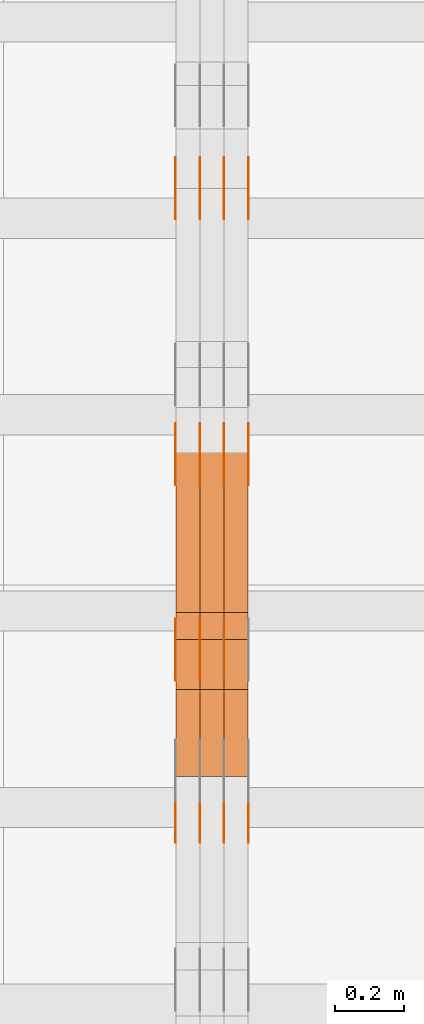
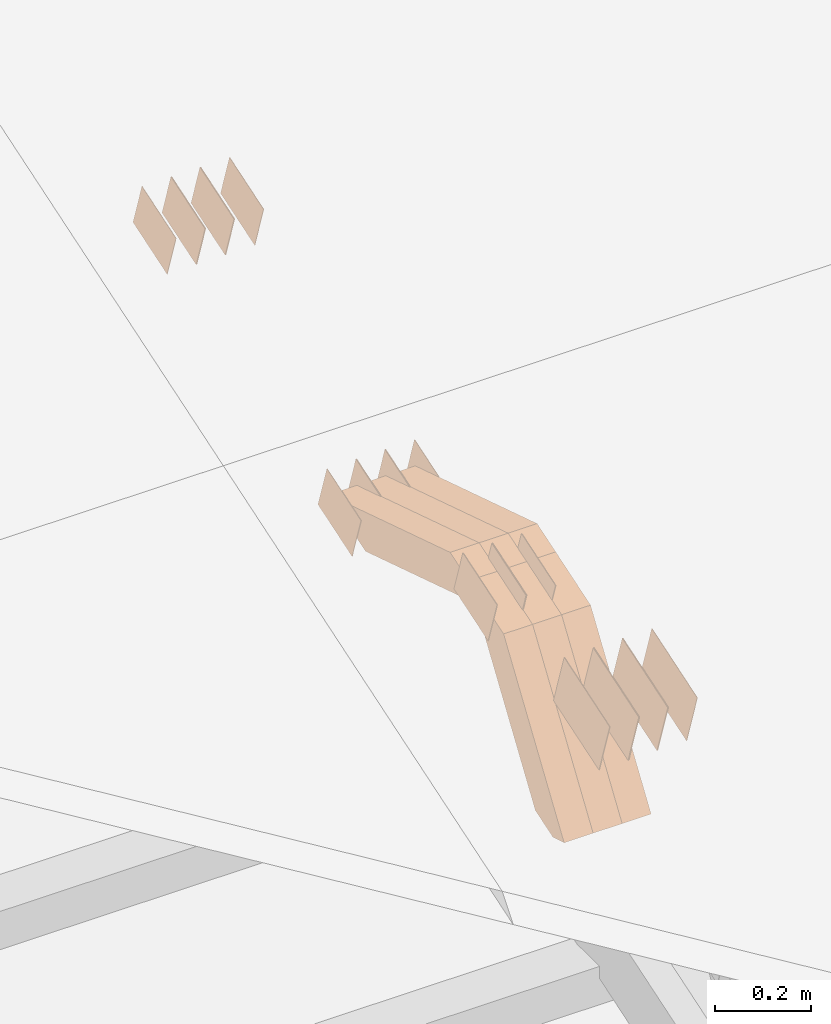
# One storey, part 125 of 385: 28 proxies.
"""IFC2X3 building model written with IfcOpenShell, lengths in millimetres."""

from ifc_helpers import new_model, entity, si_unit, converted_unit, derived_unit, direction, frame, origin, place, context, subcontext, project, spatial, polyline, outline, extrude, source, transform, mapped, material, type_object, type_shapes, element, save


model = new_model("IFC2X3")

# Units and contexts
model_context = context("Model", 3, precision=0.01, world=origin(), true_north=direction((6.12303176911189e-17, 1.0)))
body_context = subcontext(model_context, "Body", "Model", "MODEL_VIEW")
ifc_project = project(units=[si_unit("LENGTHUNIT", "METRE", prefix="MILLI"), si_unit("AREAUNIT", "SQUARE_METRE"), si_unit("VOLUMEUNIT", "CUBIC_METRE"), converted_unit("PLANEANGLEUNIT", "DEGREE", entity("IfcRatioMeasure", 0.0174532925199433), si_unit("PLANEANGLEUNIT", "RADIAN"), dimensions=[0, 0, 0, 0, 0, 0, 0]), si_unit("MASSUNIT", "GRAM", prefix="KILO"), derived_unit("MASSDENSITYUNIT", [(si_unit("MASSUNIT", "GRAM", prefix="KILO"), 1), (si_unit("LENGTHUNIT", "METRE"), -3)]), si_unit("TIMEUNIT", "SECOND"), si_unit("FREQUENCYUNIT", "HERTZ"), si_unit("THERMODYNAMICTEMPERATUREUNIT", "DEGREE_CELSIUS"), derived_unit("THERMALTRANSMITTANCEUNIT", [(si_unit("MASSUNIT", "GRAM", prefix="KILO"), 1), (si_unit("THERMODYNAMICTEMPERATUREUNIT", "KELVIN"), -1), (si_unit("TIMEUNIT", "SECOND"), -3)]), derived_unit("VOLUMETRICFLOWRATEUNIT", [(si_unit("LENGTHUNIT", "METRE"), 3), (si_unit("TIMEUNIT", "SECOND"), -1)]), si_unit("ELECTRICCURRENTUNIT", "AMPERE"), si_unit("ELECTRICVOLTAGEUNIT", "VOLT"), si_unit("POWERUNIT", "WATT"), si_unit("FORCEUNIT", "NEWTON", prefix="KILO"), si_unit("ILLUMINANCEUNIT", "LUX"), si_unit("LUMINOUSFLUXUNIT", "LUMEN"), si_unit("LUMINOUSINTENSITYUNIT", "CANDELA"), derived_unit("USERDEFINED", [(si_unit("MASSUNIT", "GRAM", prefix="KILO"), -1), (si_unit("LENGTHUNIT", "METRE"), -2), (si_unit("TIMEUNIT", "SECOND"), 3), (si_unit("LUMINOUSFLUXUNIT", "LUMEN"), 1)]), derived_unit("LINEARVELOCITYUNIT", [(si_unit("LENGTHUNIT", "METRE"), 1), (si_unit("TIMEUNIT", "SECOND"), -1)]), si_unit("PRESSUREUNIT", "PASCAL"), derived_unit("USERDEFINED", [(si_unit("LENGTHUNIT", "METRE"), -2), (si_unit("MASSUNIT", "GRAM", prefix="KILO"), 1), (si_unit("TIMEUNIT", "SECOND"), -2)])], contexts=[model_context])

# Site, building, storey
site_placement = place(None, origin())
site = spatial("IfcSite", under=ifc_project, at=site_placement, CompositionType="ELEMENT")
building_placement = place(site_placement, origin())
building = spatial("IfcBuilding", under=site, at=building_placement, CompositionType="ELEMENT")
storey_placement = place(building_placement, origin())
storey = spatial("IfcBuildingStorey", under=building, at=storey_placement, Name="Default", CompositionType="ELEMENT", Elevation=0.0)

# Proxies
ifc_material_1 = material(Name="IfcSurfaceStyle #310726")
building_element_proxy_type_1 = type_object("IfcBuildingElementProxyType", PredefinedType="NOTDEFINED", material=ifc_material_1)
shared_shape_1 = source(origin(), body_context, "Body", "SweptSolid", [
    extrude(outline(polyline([(-74.9998754286198, -60.0000016373433), (74.9998605591145, -60.0000016373433), (74.999875428618, 60.0000016373433), (-74.9998605591127, 60.0000016373433), (-74.9998754286198, -60.0000016373433)])), frame((75.0007059026038, 60.000210935219, 0.0), z_axis=(0.0, 0.0, 1.0), x_axis=(-1.0, 0.0, 0.0)), (0.0, 0.0, 1.0), 1.3),
])
type_shapes(building_element_proxy_type_1, [shared_shape_1])
proxy_1_placement = place(building_placement, frame((24386.3, 6760.15341914203, 1372.60670336718), z_axis=(-1.0, 0.0, 0.0), x_axis=(0.0, 0.951056516295124, 0.309016994375039)))
element("IfcBuildingElementProxy", 1, at=proxy_1_placement, inside=storey, type_object=building_element_proxy_type_1, material=ifc_material_1, context=body_context, shape_type="MappedRepresentation", body=[
    mapped(shared_shape_1, transform((0.0, 0.0, 0.0), scale=1.0)),
])
ifc_material_2 = material(Name="IfcSurfaceStyle #310669")
building_element_proxy_type_2 = type_object("IfcBuildingElementProxyType", PredefinedType="NOTDEFINED", material=ifc_material_2)
shared_shape_2 = source(origin(), body_context, "Body", "SweptSolid", [
    extrude(outline(polyline([(-74.9998754286198, -60.0000016373433), (74.9998605591145, -60.0000016373433), (74.999875428618, 60.0000016373433), (-74.9998605591127, 60.0000016373433), (-74.9998754286198, -60.0000016373433)])), frame((75.0007059026038, 60.000210935219, 0.0), z_axis=(0.0, 0.0, 1.0), x_axis=(-1.0, 0.0, 0.0)), (0.0, 0.0, 1.0), 1.3),
])
type_shapes(building_element_proxy_type_2, [shared_shape_2])
proxy_2_placement = place(building_placement, frame((24315.0, 6760.15341914203, 1372.60670336718), z_axis=(-1.0, 0.0, 0.0), x_axis=(0.0, 0.951056516295124, 0.309016994375039)))
element("IfcBuildingElementProxy", 2, at=proxy_2_placement, inside=storey, type_object=building_element_proxy_type_2, material=ifc_material_2, context=body_context, shape_type="MappedRepresentation", body=[
    mapped(shared_shape_2, transform((0.0, 0.0, 0.0), scale=1.0)),
])
ifc_material_3 = material(Name="IfcSurfaceStyle #310612")
building_element_proxy_type_3 = type_object("IfcBuildingElementProxyType", PredefinedType="NOTDEFINED", material=ifc_material_3)
shared_shape_3 = source(origin(), body_context, "Body", "SweptSolid", [
    extrude(outline(polyline([(-74.9998754286198, -60.0000016373433), (74.9998605591145, -60.0000016373433), (74.999875428618, 60.0000016373433), (-74.9998605591127, 60.0000016373433), (-74.9998754286198, -60.0000016373433)])), frame((75.0007059026038, 60.000210935219, 0.0), z_axis=(0.0, 0.0, 1.0), x_axis=(-1.0, 0.0, 0.0)), (0.0, 0.0, 1.0), 1.3),
])
type_shapes(building_element_proxy_type_3, [shared_shape_3])
proxy_3_placement = place(building_placement, frame((24316.3, 6760.15341914203, 1372.60670336718), z_axis=(-1.0, 0.0, 0.0), x_axis=(0.0, 0.951056516295124, 0.309016994375039)))
element("IfcBuildingElementProxy", 3, at=proxy_3_placement, inside=storey, type_object=building_element_proxy_type_3, material=ifc_material_3, context=body_context, shape_type="MappedRepresentation", body=[
    mapped(shared_shape_3, transform((0.0, 0.0, 0.0), scale=1.0)),
])
ifc_material_4 = material(Name="IfcSurfaceStyle #310555")
building_element_proxy_type_4 = type_object("IfcBuildingElementProxyType", PredefinedType="NOTDEFINED", material=ifc_material_4)
shared_shape_4 = source(origin(), body_context, "Body", "SweptSolid", [
    extrude(outline(polyline([(-74.9998754286198, -60.0000016373433), (74.9998605591145, -60.0000016373433), (74.999875428618, 60.0000016373433), (-74.9998605591127, 60.0000016373433), (-74.9998754286198, -60.0000016373433)])), frame((75.0007059026038, 60.000210935219, 0.0), z_axis=(0.0, 0.0, 1.0), x_axis=(-1.0, 0.0, 0.0)), (0.0, 0.0, 1.0), 1.29999999999999),
])
type_shapes(building_element_proxy_type_4, [shared_shape_4])
proxy_4_placement = place(building_placement, frame((24245.0, 6760.15341914203, 1372.60670336718), z_axis=(-1.0, 0.0, 0.0), x_axis=(0.0, 0.951056516295124, 0.309016994375039)))
element("IfcBuildingElementProxy", 4, at=proxy_4_placement, inside=storey, type_object=building_element_proxy_type_4, material=ifc_material_4, context=body_context, shape_type="MappedRepresentation", body=[
    mapped(shared_shape_4, transform((0.0, 0.0, 0.0), scale=1.0)),
])
ifc_material_5 = material(Name="IfcSurfaceStyle #310498")
building_element_proxy_type_5 = type_object("IfcBuildingElementProxyType", PredefinedType="NOTDEFINED", material=ifc_material_5)
shared_shape_5 = source(origin(), body_context, "Body", "SweptSolid", [
    extrude(outline(polyline([(-74.9998754286198, -60.0000016373433), (74.9998605591145, -60.0000016373433), (74.999875428618, 60.0000016373433), (-74.9998605591127, 60.0000016373433), (-74.9998754286198, -60.0000016373433)])), frame((75.0007059026038, 60.000210935219, 0.0), z_axis=(0.0, 0.0, 1.0), x_axis=(-1.0, 0.0, 0.0)), (0.0, 0.0, 1.0), 1.29999999999999),
])
type_shapes(building_element_proxy_type_5, [shared_shape_5])
proxy_5_placement = place(building_placement, frame((24246.3, 6760.15341914203, 1372.60670336718), z_axis=(-1.0, 0.0, 0.0), x_axis=(0.0, 0.951056516295124, 0.309016994375039)))
element("IfcBuildingElementProxy", 5, at=proxy_5_placement, inside=storey, type_object=building_element_proxy_type_5, material=ifc_material_5, context=body_context, shape_type="MappedRepresentation", body=[
    mapped(shared_shape_5, transform((0.0, 0.0, 0.0), scale=1.0)),
])
ifc_material_6 = material(Name="IfcSurfaceStyle #310441")
building_element_proxy_type_6 = type_object("IfcBuildingElementProxyType", PredefinedType="NOTDEFINED", material=ifc_material_6)
shared_shape_6 = source(origin(), body_context, "Body", "SweptSolid", [
    extrude(outline(polyline([(-74.9998754286198, -60.0000016373433), (74.9998605591145, -60.0000016373433), (74.999875428618, 60.0000016373433), (-74.9998605591127, 60.0000016373433), (-74.9998754286198, -60.0000016373433)])), frame((75.0007059026038, 60.000210935219, 0.0), z_axis=(0.0, 0.0, 1.0), x_axis=(-1.0, 0.0, 0.0)), (0.0, 0.0, 1.0), 1.29999999999999),
])
type_shapes(building_element_proxy_type_6, [shared_shape_6])
proxy_6_placement = place(building_placement, frame((24175.0, 6760.15341914203, 1372.60670336718), z_axis=(-1.0, 0.0, 0.0), x_axis=(0.0, 0.951056516295124, 0.309016994375039)))
element("IfcBuildingElementProxy", 6, at=proxy_6_placement, inside=storey, type_object=building_element_proxy_type_6, material=ifc_material_6, context=body_context, shape_type="MappedRepresentation", body=[
    mapped(shared_shape_6, transform((0.0, 0.0, 0.0), scale=1.0)),
])
ifc_material_7 = material(Name="IfcSurfaceStyle #304570")
building_element_proxy_type_7 = type_object("IfcBuildingElementProxyType", PredefinedType="NOTDEFINED", material=ifc_material_7)
shared_shape_7 = source(origin(), body_context, "Body", "SweptSolid", [
    extrude(outline(polyline([(-74.9998801438441, -60.0000306612856), (74.9998747047876, -60.0000306612856), (74.9998707133936, 60.0000306612856), (-74.9998652743371, 60.0000306612856), (-74.9998801438441, -60.0000306612856)])), frame((75.0000206139493, 60.0000306612856, 0.0), z_axis=(0.0, 0.0, 1.0), x_axis=(-1.0, 0.0, 0.0)), (0.0, 0.0, 1.0), 1.3),
])
type_shapes(building_element_proxy_type_7, [shared_shape_7])
proxy_7_placement = place(building_placement, frame((24386.3, 5987.08381858242, 1121.42116774683), z_axis=(-1.0, 0.0, 0.0), x_axis=(0.0, 0.951056516295124, 0.309016994375039)))
element("IfcBuildingElementProxy", 7, at=proxy_7_placement, inside=storey, type_object=building_element_proxy_type_7, material=ifc_material_7, context=body_context, shape_type="MappedRepresentation", body=[
    mapped(shared_shape_7, transform((0.0, 0.0, 0.0), scale=1.0)),
])
ifc_material_8 = material(Name="IfcSurfaceStyle #304513")
building_element_proxy_type_8 = type_object("IfcBuildingElementProxyType", PredefinedType="NOTDEFINED", material=ifc_material_8)
shared_shape_8 = source(origin(), body_context, "Body", "SweptSolid", [
    extrude(outline(polyline([(-74.9998801438441, -60.0000306612856), (74.9998747047876, -60.0000306612856), (74.9998707133936, 60.0000306612856), (-74.9998652743371, 60.0000306612856), (-74.9998801438441, -60.0000306612856)])), frame((75.0000206139493, 60.0000306612856, 0.0), z_axis=(0.0, 0.0, 1.0), x_axis=(-1.0, 0.0, 0.0)), (0.0, 0.0, 1.0), 1.3),
])
type_shapes(building_element_proxy_type_8, [shared_shape_8])
proxy_8_placement = place(building_placement, frame((24315.0, 5987.08381858242, 1121.42116774683), z_axis=(-1.0, 0.0, 0.0), x_axis=(0.0, 0.951056516295124, 0.309016994375039)))
element("IfcBuildingElementProxy", 8, at=proxy_8_placement, inside=storey, type_object=building_element_proxy_type_8, material=ifc_material_8, context=body_context, shape_type="MappedRepresentation", body=[
    mapped(shared_shape_8, transform((0.0, 0.0, 0.0), scale=1.0)),
])
ifc_material_9 = material(Name="IfcSurfaceStyle #304456")
building_element_proxy_type_9 = type_object("IfcBuildingElementProxyType", PredefinedType="NOTDEFINED", material=ifc_material_9)
shared_shape_9 = source(origin(), body_context, "Body", "SweptSolid", [
    extrude(outline(polyline([(-74.9998801438441, -60.0000306612856), (74.9998747047876, -60.0000306612856), (74.9998707133936, 60.0000306612856), (-74.9998652743371, 60.0000306612856), (-74.9998801438441, -60.0000306612856)])), frame((75.0000206139493, 60.0000306612856, 0.0), z_axis=(0.0, 0.0, 1.0), x_axis=(-1.0, 0.0, 0.0)), (0.0, 0.0, 1.0), 1.3),
])
type_shapes(building_element_proxy_type_9, [shared_shape_9])
proxy_9_placement = place(building_placement, frame((24316.3, 5987.08381858242, 1121.42116774683), z_axis=(-1.0, 0.0, 0.0), x_axis=(0.0, 0.951056516295124, 0.309016994375039)))
element("IfcBuildingElementProxy", 9, at=proxy_9_placement, inside=storey, type_object=building_element_proxy_type_9, material=ifc_material_9, context=body_context, shape_type="MappedRepresentation", body=[
    mapped(shared_shape_9, transform((0.0, 0.0, 0.0), scale=1.0)),
])
ifc_material_10 = material(Name="IfcSurfaceStyle #304399")
building_element_proxy_type_10 = type_object("IfcBuildingElementProxyType", PredefinedType="NOTDEFINED", material=ifc_material_10)
shared_shape_10 = source(origin(), body_context, "Body", "SweptSolid", [
    extrude(outline(polyline([(-74.9998801438441, -60.0000306612856), (74.9998747047876, -60.0000306612856), (74.9998707133936, 60.0000306612856), (-74.9998652743371, 60.0000306612856), (-74.9998801438441, -60.0000306612856)])), frame((75.0000206139493, 60.0000306612856, 0.0), z_axis=(0.0, 0.0, 1.0), x_axis=(-1.0, 0.0, 0.0)), (0.0, 0.0, 1.0), 1.29999999999999),
])
type_shapes(building_element_proxy_type_10, [shared_shape_10])
proxy_10_placement = place(building_placement, frame((24245.0, 5987.08381858242, 1121.42116774683), z_axis=(-1.0, 0.0, 0.0), x_axis=(0.0, 0.951056516295124, 0.309016994375039)))
element("IfcBuildingElementProxy", 10, at=proxy_10_placement, inside=storey, type_object=building_element_proxy_type_10, material=ifc_material_10, context=body_context, shape_type="MappedRepresentation", body=[
    mapped(shared_shape_10, transform((0.0, 0.0, 0.0), scale=1.0)),
])
ifc_material_11 = material(Name="IfcSurfaceStyle #304342")
building_element_proxy_type_11 = type_object("IfcBuildingElementProxyType", PredefinedType="NOTDEFINED", material=ifc_material_11)
shared_shape_11 = source(origin(), body_context, "Body", "SweptSolid", [
    extrude(outline(polyline([(-74.9998801438441, -60.0000306612856), (74.9998747047876, -60.0000306612856), (74.9998707133936, 60.0000306612856), (-74.9998652743371, 60.0000306612856), (-74.9998801438441, -60.0000306612856)])), frame((75.0000206139493, 60.0000306612856, 0.0), z_axis=(0.0, 0.0, 1.0), x_axis=(-1.0, 0.0, 0.0)), (0.0, 0.0, 1.0), 1.29999999999999),
])
type_shapes(building_element_proxy_type_11, [shared_shape_11])
proxy_11_placement = place(building_placement, frame((24246.3, 5987.08381858242, 1121.42116774683), z_axis=(-1.0, 0.0, 0.0), x_axis=(0.0, 0.951056516295124, 0.309016994375039)))
element("IfcBuildingElementProxy", 11, at=proxy_11_placement, inside=storey, type_object=building_element_proxy_type_11, material=ifc_material_11, context=body_context, shape_type="MappedRepresentation", body=[
    mapped(shared_shape_11, transform((0.0, 0.0, 0.0), scale=1.0)),
])
ifc_material_12 = material(Name="IfcSurfaceStyle #304285")
building_element_proxy_type_12 = type_object("IfcBuildingElementProxyType", PredefinedType="NOTDEFINED", material=ifc_material_12)
shared_shape_12 = source(origin(), body_context, "Body", "SweptSolid", [
    extrude(outline(polyline([(-74.9998801438441, -60.0000306612856), (74.9998747047876, -60.0000306612856), (74.9998707133936, 60.0000306612856), (-74.9998652743371, 60.0000306612856), (-74.9998801438441, -60.0000306612856)])), frame((75.0000206139493, 60.0000306612856, 0.0), z_axis=(0.0, 0.0, 1.0), x_axis=(-1.0, 0.0, 0.0)), (0.0, 0.0, 1.0), 1.29999999999999),
])
type_shapes(building_element_proxy_type_12, [shared_shape_12])
proxy_12_placement = place(building_placement, frame((24175.0, 5987.08381858242, 1121.42116774683), z_axis=(-1.0, 0.0, 0.0), x_axis=(0.0, 0.951056516295124, 0.309016994375039)))
element("IfcBuildingElementProxy", 12, at=proxy_12_placement, inside=storey, type_object=building_element_proxy_type_12, material=ifc_material_12, context=body_context, shape_type="MappedRepresentation", body=[
    mapped(shared_shape_12, transform((0.0, 0.0, 0.0), scale=1.0)),
])
ifc_material_13 = material(Name="IfcSurfaceStyle #298984")
building_element_proxy_type_13 = type_object("IfcBuildingElementProxyType", PredefinedType="NOTDEFINED", material=ifc_material_13)
shared_shape_13 = source(origin(), body_context, "Body", "SweptSolid", [
    extrude(outline(polyline([(-74.9998565677224, -60.0000596852342), (74.9998794200083, -60.0000596852342), (74.9998565677242, 60.0000596852342), (-74.9998794200101, 60.0000596852342), (-74.9998565677224, -60.0000596852342)])), frame((74.9998794200083, 60.0000596852342, 0.0), z_axis=(0.0, 0.0, 1.0), x_axis=(-1.0, 0.0, 0.0)), (0.0, 0.0, 1.0), 1.3),
])
type_shapes(building_element_proxy_type_13, [shared_shape_13])
proxy_13_placement = place(building_placement, frame((24316.3, 5418.6991737875, 1250.81341892098), z_axis=(-1.0, 0.0, 0.0), x_axis=(0.0, 0.951056516295154, 0.309016994374948)))
element("IfcBuildingElementProxy", 13, at=proxy_13_placement, inside=storey, type_object=building_element_proxy_type_13, material=ifc_material_13, context=body_context, shape_type="MappedRepresentation", body=[
    mapped(shared_shape_13, transform((0.0, 0.0, 0.0), scale=1.0)),
])
ifc_material_14 = material(Name="IfcSurfaceStyle #298927")
building_element_proxy_type_14 = type_object("IfcBuildingElementProxyType", PredefinedType="NOTDEFINED", material=ifc_material_14)
shared_shape_14 = source(origin(), body_context, "Body", "SweptSolid", [
    extrude(outline(polyline([(-74.9998565677224, -60.0000596852342), (74.9998794200083, -60.0000596852342), (74.9998565677242, 60.0000596852342), (-74.9998794200101, 60.0000596852342), (-74.9998565677224, -60.0000596852342)])), frame((74.9998794200083, 60.0000596852342, 0.0), z_axis=(0.0, 0.0, 1.0), x_axis=(-1.0, 0.0, 0.0)), (0.0, 0.0, 1.0), 1.29999999999999),
])
type_shapes(building_element_proxy_type_14, [shared_shape_14])
proxy_14_placement = place(building_placement, frame((24245.0, 5418.6991737875, 1250.81341892098), z_axis=(-1.0, 0.0, 0.0), x_axis=(0.0, 0.951056516295154, 0.309016994374948)))
element("IfcBuildingElementProxy", 14, at=proxy_14_placement, inside=storey, type_object=building_element_proxy_type_14, material=ifc_material_14, context=body_context, shape_type="MappedRepresentation", body=[
    mapped(shared_shape_14, transform((0.0, 0.0, 0.0), scale=1.0)),
])
ifc_material_15 = material(Name="IfcSurfaceStyle #298870")
building_element_proxy_type_15 = type_object("IfcBuildingElementProxyType", PredefinedType="NOTDEFINED", material=ifc_material_15)
shared_shape_15 = source(origin(), body_context, "Body", "SweptSolid", [
    extrude(outline(polyline([(-74.9998565677224, -60.0000596852342), (74.9998794200083, -60.0000596852342), (74.9998565677242, 60.0000596852342), (-74.9998794200101, 60.0000596852342), (-74.9998565677224, -60.0000596852342)])), frame((74.9998794200083, 60.0000596852342, 0.0), z_axis=(0.0, 0.0, 1.0), x_axis=(-1.0, 0.0, 0.0)), (0.0, 0.0, 1.0), 1.29999999999999),
])
type_shapes(building_element_proxy_type_15, [shared_shape_15])
proxy_15_placement = place(building_placement, frame((24246.3, 5418.6991737875, 1250.81341892098), z_axis=(-1.0, 0.0, 0.0), x_axis=(0.0, 0.951056516295154, 0.309016994374948)))
element("IfcBuildingElementProxy", 15, at=proxy_15_placement, inside=storey, type_object=building_element_proxy_type_15, material=ifc_material_15, context=body_context, shape_type="MappedRepresentation", body=[
    mapped(shared_shape_15, transform((0.0, 0.0, 0.0), scale=1.0)),
])
ifc_material_16 = material(Name="IfcSurfaceStyle #298813")
building_element_proxy_type_16 = type_object("IfcBuildingElementProxyType", PredefinedType="NOTDEFINED", material=ifc_material_16)
shared_shape_16 = source(origin(), body_context, "Body", "SweptSolid", [
    extrude(outline(polyline([(-74.9998565677224, -60.0000596852342), (74.9998794200083, -60.0000596852342), (74.9998565677242, 60.0000596852342), (-74.9998794200101, 60.0000596852342), (-74.9998565677224, -60.0000596852342)])), frame((74.9998794200083, 60.0000596852342, 0.0), z_axis=(0.0, 0.0, 1.0), x_axis=(-1.0, 0.0, 0.0)), (0.0, 0.0, 1.0), 1.29999999999999),
])
type_shapes(building_element_proxy_type_16, [shared_shape_16])
proxy_16_placement = place(building_placement, frame((24175.0, 5418.6991737875, 1250.81341892098), z_axis=(-1.0, 0.0, 0.0), x_axis=(0.0, 0.951056516295154, 0.309016994374948)))
element("IfcBuildingElementProxy", 16, at=proxy_16_placement, inside=storey, type_object=building_element_proxy_type_16, material=ifc_material_16, context=body_context, shape_type="MappedRepresentation", body=[
    mapped(shared_shape_16, transform((0.0, 0.0, 0.0), scale=1.0)),
])
ifc_material_17 = material(Name="IfcSurfaceStyle #295678")
building_element_proxy_type_17 = type_object("IfcBuildingElementProxyType", PredefinedType="NOTDEFINED", material=ifc_material_17)
shared_shape_17 = source(origin(), body_context, "Body", "SweptSolid", [
    extrude(outline(polyline([(-99.9996257846169, -71.999973710258), (100.000009625089, -71.999973710258), (99.9996257846187, 71.999973710258), (-100.000009625091, 71.999973710258), (-99.9996257846169, -71.999973710258)])), frame((100.000083496635, 72.0000008245779, 0.0), z_axis=(0.0, 0.0, 1.0), x_axis=(-1.0, 0.0, 0.0)), (0.0, 0.0, 1.0), 1.3),
])
type_shapes(building_element_proxy_type_17, [shared_shape_17])
proxy_17_placement = place(building_placement, frame((24386.3, 4947.73195917316, 1225.53937157357), z_axis=(-1.0, 0.0, 0.0), x_axis=(0.0, 0.951056516295154, 0.309016994374948)))
element("IfcBuildingElementProxy", 17, at=proxy_17_placement, inside=storey, type_object=building_element_proxy_type_17, material=ifc_material_17, context=body_context, shape_type="MappedRepresentation", body=[
    mapped(shared_shape_17, transform((0.0, 0.0, 0.0), scale=1.0)),
])
ifc_material_18 = material(Name="IfcSurfaceStyle #295621")
building_element_proxy_type_18 = type_object("IfcBuildingElementProxyType", PredefinedType="NOTDEFINED", material=ifc_material_18)
shared_shape_18 = source(origin(), body_context, "Body", "SweptSolid", [
    extrude(outline(polyline([(-99.9996257846169, -71.999973710258), (100.000009625089, -71.999973710258), (99.9996257846187, 71.999973710258), (-100.000009625091, 71.999973710258), (-99.9996257846169, -71.999973710258)])), frame((100.000083496635, 72.0000008245779, 0.0), z_axis=(0.0, 0.0, 1.0), x_axis=(-1.0, 0.0, 0.0)), (0.0, 0.0, 1.0), 1.3),
])
type_shapes(building_element_proxy_type_18, [shared_shape_18])
proxy_18_placement = place(building_placement, frame((24315.0, 4947.73195917316, 1225.53937157357), z_axis=(-1.0, 0.0, 0.0), x_axis=(0.0, 0.951056516295154, 0.309016994374948)))
element("IfcBuildingElementProxy", 18, at=proxy_18_placement, inside=storey, type_object=building_element_proxy_type_18, material=ifc_material_18, context=body_context, shape_type="MappedRepresentation", body=[
    mapped(shared_shape_18, transform((0.0, 0.0, 0.0), scale=1.0)),
])
ifc_material_19 = material(Name="IfcSurfaceStyle #295564")
building_element_proxy_type_19 = type_object("IfcBuildingElementProxyType", PredefinedType="NOTDEFINED", material=ifc_material_19)
shared_shape_19 = source(origin(), body_context, "Body", "SweptSolid", [
    extrude(outline(polyline([(-99.9996257846169, -71.999973710258), (100.000009625089, -71.999973710258), (99.9996257846187, 71.999973710258), (-100.000009625091, 71.999973710258), (-99.9996257846169, -71.999973710258)])), frame((100.000083496635, 72.0000008245779, 0.0), z_axis=(0.0, 0.0, 1.0), x_axis=(-1.0, 0.0, 0.0)), (0.0, 0.0, 1.0), 1.3),
])
type_shapes(building_element_proxy_type_19, [shared_shape_19])
proxy_19_placement = place(building_placement, frame((24316.3, 4947.73195917316, 1225.53937157357), z_axis=(-1.0, 0.0, 0.0), x_axis=(0.0, 0.951056516295154, 0.309016994374948)))
element("IfcBuildingElementProxy", 19, at=proxy_19_placement, inside=storey, type_object=building_element_proxy_type_19, material=ifc_material_19, context=body_context, shape_type="MappedRepresentation", body=[
    mapped(shared_shape_19, transform((0.0, 0.0, 0.0), scale=1.0)),
])
ifc_material_20 = material(Name="IfcSurfaceStyle #295507")
building_element_proxy_type_20 = type_object("IfcBuildingElementProxyType", PredefinedType="NOTDEFINED", material=ifc_material_20)
shared_shape_20 = source(origin(), body_context, "Body", "SweptSolid", [
    extrude(outline(polyline([(-99.9996257846169, -71.999973710258), (100.000009625089, -71.999973710258), (99.9996257846187, 71.999973710258), (-100.000009625091, 71.999973710258), (-99.9996257846169, -71.999973710258)])), frame((100.000083496635, 72.0000008245779, 0.0), z_axis=(0.0, 0.0, 1.0), x_axis=(-1.0, 0.0, 0.0)), (0.0, 0.0, 1.0), 1.29999999999998),
])
type_shapes(building_element_proxy_type_20, [shared_shape_20])
proxy_20_placement = place(building_placement, frame((24245.0, 4947.73195917316, 1225.53937157357), z_axis=(-1.0, 0.0, 0.0), x_axis=(0.0, 0.951056516295154, 0.309016994374948)))
element("IfcBuildingElementProxy", 20, at=proxy_20_placement, inside=storey, type_object=building_element_proxy_type_20, material=ifc_material_20, context=body_context, shape_type="MappedRepresentation", body=[
    mapped(shared_shape_20, transform((0.0, 0.0, 0.0), scale=1.0)),
])
ifc_material_21 = material(Name="IfcSurfaceStyle #295450")
building_element_proxy_type_21 = type_object("IfcBuildingElementProxyType", PredefinedType="NOTDEFINED", material=ifc_material_21)
shared_shape_21 = source(origin(), body_context, "Body", "SweptSolid", [
    extrude(outline(polyline([(-99.9996257846169, -71.999973710258), (100.000009625089, -71.999973710258), (99.9996257846187, 71.999973710258), (-100.000009625091, 71.999973710258), (-99.9996257846169, -71.999973710258)])), frame((100.000083496635, 72.0000008245779, 0.0), z_axis=(0.0, 0.0, 1.0), x_axis=(-1.0, 0.0, 0.0)), (0.0, 0.0, 1.0), 1.29999999999998),
])
type_shapes(building_element_proxy_type_21, [shared_shape_21])
proxy_21_placement = place(building_placement, frame((24246.3, 4947.73195917316, 1225.53937157357), z_axis=(-1.0, 0.0, 0.0), x_axis=(0.0, 0.951056516295154, 0.309016994374948)))
element("IfcBuildingElementProxy", 21, at=proxy_21_placement, inside=storey, type_object=building_element_proxy_type_21, material=ifc_material_21, context=body_context, shape_type="MappedRepresentation", body=[
    mapped(shared_shape_21, transform((0.0, 0.0, 0.0), scale=1.0)),
])
ifc_material_22 = material(Name="IfcSurfaceStyle #295393")
building_element_proxy_type_22 = type_object("IfcBuildingElementProxyType", PredefinedType="NOTDEFINED", material=ifc_material_22)
shared_shape_22 = source(origin(), body_context, "Body", "SweptSolid", [
    extrude(outline(polyline([(-99.9996257846169, -71.999973710258), (100.000009625089, -71.999973710258), (99.9996257846187, 71.999973710258), (-100.000009625091, 71.999973710258), (-99.9996257846169, -71.999973710258)])), frame((100.000083496635, 72.0000008245779, 0.0), z_axis=(0.0, 0.0, 1.0), x_axis=(-1.0, 0.0, 0.0)), (0.0, 0.0, 1.0), 1.29999999999999),
])
type_shapes(building_element_proxy_type_22, [shared_shape_22])
proxy_22_placement = place(building_placement, frame((24175.0, 4947.73195917316, 1225.53937157357), z_axis=(-1.0, 0.0, 0.0), x_axis=(0.0, 0.951056516295154, 0.309016994374948)))
element("IfcBuildingElementProxy", 22, at=proxy_22_placement, inside=storey, type_object=building_element_proxy_type_22, material=ifc_material_22, context=body_context, shape_type="MappedRepresentation", body=[
    mapped(shared_shape_22, transform((0.0, 0.0, 0.0), scale=1.0)),
])
ifc_material_23 = material(Name="IfcSurfaceStyle #286336")
building_element_proxy_type_23 = type_object("IfcBuildingElementProxyType", Name="T1-W15 286334", PredefinedType="NOTDEFINED", material=ifc_material_23)
shared_shape_23 = source(origin(), body_context, "Body", "SweptSolid", [
    extrude(outline(polyline([(-243.398341390642, -47.5000170814535), (237.775741169608, -47.5000170814535), (224.054017709933, 0.000127777485579883), (157.692261395711, 47.4999531927108), (-376.12367888461, 47.4999531927107), (-243.398341390642, -47.5000170814535)])), frame((237.77637044506, 47.5003404768297, 0.0), z_axis=(0.0, 0.0, 1.0), x_axis=(-1.0, 0.0, 0.0)), (0.0, 0.0, 1.0), 70.0),
])
type_shapes(building_element_proxy_type_23, [shared_shape_23])
proxy_23_placement = place(building_placement, frame((24385.0, 5540.23242178142, 1288.84274826279), z_axis=(-1.0, 0.0, 0.0), x_axis=(0.0, 0.95322291386448, -0.302268219440466)))
element("IfcBuildingElementProxy", 23, at=proxy_23_placement, inside=storey, type_object=building_element_proxy_type_23, material=ifc_material_23, Name="T1-W15", context=body_context, shape_type="MappedRepresentation", body=[
    mapped(shared_shape_23, transform((0.0, 0.0, 0.0), scale=1.0)),
])
ifc_material_24 = material(Name="IfcSurfaceStyle #286270")
building_element_proxy_type_24 = type_object("IfcBuildingElementProxyType", Name="T1-W15 286268", PredefinedType="NOTDEFINED", material=ifc_material_24)
shared_shape_24 = source(origin(), body_context, "Body", "SweptSolid", [
    extrude(outline(polyline([(-243.398341390642, -47.5000170814535), (237.775741169608, -47.5000170814535), (224.054017709933, 0.000127777485579883), (157.692261395711, 47.4999531927108), (-376.12367888461, 47.4999531927107), (-243.398341390642, -47.5000170814535)])), frame((237.77637044506, 47.5003404768297, 0.0), z_axis=(0.0, 0.0, 1.0), x_axis=(-1.0, 0.0, 0.0)), (0.0, 0.0, 1.0), 70.0),
])
type_shapes(building_element_proxy_type_24, [shared_shape_24])
proxy_24_placement = place(building_placement, frame((24315.0, 5540.23242178142, 1288.84274826279), z_axis=(-1.0, 0.0, 0.0), x_axis=(0.0, 0.95322291386448, -0.302268219440466)))
element("IfcBuildingElementProxy", 24, at=proxy_24_placement, inside=storey, type_object=building_element_proxy_type_24, material=ifc_material_24, Name="T1-W15", context=body_context, shape_type="MappedRepresentation", body=[
    mapped(shared_shape_24, transform((0.0, 0.0, 0.0), scale=1.0)),
])
ifc_material_25 = material(Name="IfcSurfaceStyle #286204")
building_element_proxy_type_25 = type_object("IfcBuildingElementProxyType", Name="T1-W15 286202", PredefinedType="NOTDEFINED", material=ifc_material_25)
shared_shape_25 = source(origin(), body_context, "Body", "SweptSolid", [
    extrude(outline(polyline([(-243.398341390642, -47.5000170814535), (237.775741169608, -47.5000170814535), (224.054017709933, 0.000127777485579883), (157.692261395711, 47.4999531927108), (-376.12367888461, 47.4999531927107), (-243.398341390642, -47.5000170814535)])), frame((237.77637044506, 47.5003404768297, 0.0), z_axis=(0.0, 0.0, 1.0), x_axis=(-1.0, 0.0, 0.0)), (0.0, 0.0, 1.0), 70.0),
])
type_shapes(building_element_proxy_type_25, [shared_shape_25])
proxy_25_placement = place(building_placement, frame((24245.0, 5540.23242178142, 1288.84274826279), z_axis=(-1.0, 0.0, 0.0), x_axis=(0.0, 0.95322291386448, -0.302268219440466)))
element("IfcBuildingElementProxy", 25, at=proxy_25_placement, inside=storey, type_object=building_element_proxy_type_25, material=ifc_material_25, Name="T1-W15", context=body_context, shape_type="MappedRepresentation", body=[
    mapped(shared_shape_25, transform((0.0, 0.0, 0.0), scale=1.0)),
])
ifc_material_26 = material(Name="IfcSurfaceStyle #285940")
building_element_proxy_type_26 = type_object("IfcBuildingElementProxyType", Name="T1-W22 285938", PredefinedType="NOTDEFINED", material=ifc_material_26)
shared_shape_26 = source(origin(), body_context, "Body", "SweptSolid", [
    extrude(outline(polyline([(-351.940486061686, -47.5005995570677), (149.451602529695, -47.5005995570676), (209.614029773051, 0.000108554198836676), (224.491670779786, 47.5010029530092), (-231.616817020846, 47.5000876069273), (-351.940486061686, -47.5005995570677)])), frame((224.491766107217, 47.5005524294596, 0.0), z_axis=(0.0, 0.0, 1.0), x_axis=(-1.0, 2.00686044286885e-06, 0.0)), (0.0, 0.0, 1.0), 70.0),
])
type_shapes(building_element_proxy_type_26, [shared_shape_26])
proxy_26_placement = place(building_placement, frame((24385.0, 5140.03125, 812.615600585936), z_axis=(-1.0, 0.0, 0.0), x_axis=(0.0, 0.554956576676696, 0.831879316970486)))
element("IfcBuildingElementProxy", 26, at=proxy_26_placement, inside=storey, type_object=building_element_proxy_type_26, material=ifc_material_26, Name="T1-W22", context=body_context, shape_type="MappedRepresentation", body=[
    mapped(shared_shape_26, transform((0.0, 0.0, 0.0), scale=1.0)),
])
ifc_material_27 = material(Name="IfcSurfaceStyle #285874")
building_element_proxy_type_27 = type_object("IfcBuildingElementProxyType", Name="T1-W22 285872", PredefinedType="NOTDEFINED", material=ifc_material_27)
shared_shape_27 = source(origin(), body_context, "Body", "SweptSolid", [
    extrude(outline(polyline([(-351.940486061686, -47.5005995570677), (149.451602529695, -47.5005995570676), (209.614029773051, 0.000108554198836676), (224.491670779786, 47.5010029530092), (-231.616817020846, 47.5000876069273), (-351.940486061686, -47.5005995570677)])), frame((224.491766107217, 47.5005524294596, 0.0), z_axis=(0.0, 0.0, 1.0), x_axis=(-1.0, 2.00686044286885e-06, 0.0)), (0.0, 0.0, 1.0), 70.0),
])
type_shapes(building_element_proxy_type_27, [shared_shape_27])
proxy_27_placement = place(building_placement, frame((24315.0, 5140.03125, 812.615600585936), z_axis=(-1.0, 0.0, 0.0), x_axis=(0.0, 0.554956576676696, 0.831879316970486)))
element("IfcBuildingElementProxy", 27, at=proxy_27_placement, inside=storey, type_object=building_element_proxy_type_27, material=ifc_material_27, Name="T1-W22", context=body_context, shape_type="MappedRepresentation", body=[
    mapped(shared_shape_27, transform((0.0, 0.0, 0.0), scale=1.0)),
])
ifc_material_28 = material(Name="IfcSurfaceStyle #285808")
building_element_proxy_type_28 = type_object("IfcBuildingElementProxyType", Name="T1-W22 285806", PredefinedType="NOTDEFINED", material=ifc_material_28)
shared_shape_28 = source(origin(), body_context, "Body", "SweptSolid", [
    extrude(outline(polyline([(-351.940486061686, -47.5005995570677), (149.451602529695, -47.5005995570676), (209.614029773051, 0.000108554198836676), (224.491670779786, 47.5010029530092), (-231.616817020846, 47.5000876069273), (-351.940486061686, -47.5005995570677)])), frame((224.491766107217, 47.5005524294596, 0.0), z_axis=(0.0, 0.0, 1.0), x_axis=(-1.0, 2.00686044286885e-06, 0.0)), (0.0, 0.0, 1.0), 70.0),
])
type_shapes(building_element_proxy_type_28, [shared_shape_28])
proxy_28_placement = place(building_placement, frame((24245.0, 5140.03125, 812.615600585936), z_axis=(-1.0, 0.0, 0.0), x_axis=(0.0, 0.554956576676696, 0.831879316970486)))
element("IfcBuildingElementProxy", 28, at=proxy_28_placement, inside=storey, type_object=building_element_proxy_type_28, material=ifc_material_28, Name="T1-W22", context=body_context, shape_type="MappedRepresentation", body=[
    mapped(shared_shape_28, transform((0.0, 0.0, 0.0), scale=1.0)),
])

save(model, "model.ifc")
